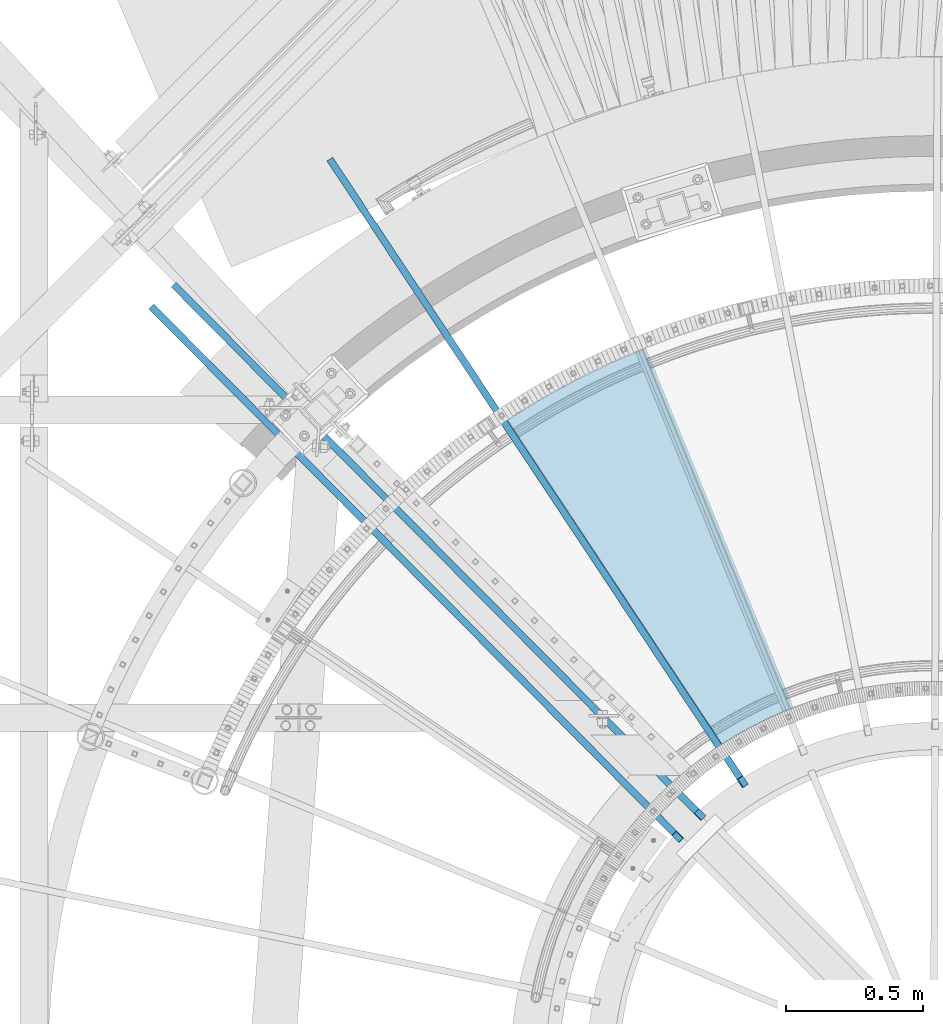
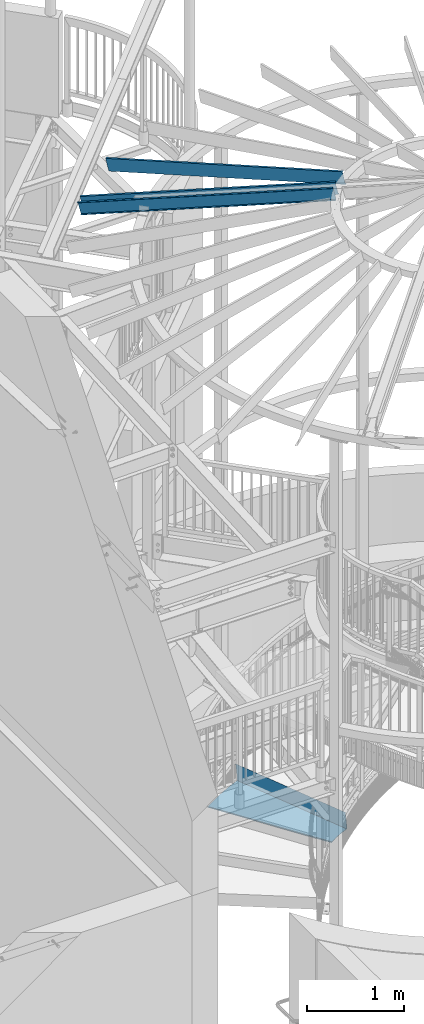
# One storey, part 353 of 975: 4 beams.
"""IFC2X3 building model written with IfcOpenShell, lengths in millimetres."""

import ifcopenshell
import ifcopenshell.guid

model = None  # the IFC model being written
_history = None  # IfcOwnerHistory: only IFC2X3 demands one
_inside = {}  # id of a spatial element -> (the spatial element, [elements in it])
_under = {}  # id of a project, library or spatial element -> (it, [spatial elements below it])
_declared = {}  # id of a project -> (the project, [libraries it declares])
_typed = {}  # id of a type object -> (the type object, [elements of that type])
_made_of = {}  # id of a material, layer set ... -> (it, [elements and type objects made of it])


def new_model(schema):
    """Start an empty IFC model of exactly this schema.

    Asked for "IFC4X3", IfcOpenShell would pick the latest addendum, in which some entities
    have other attributes; the version numbers below select the first issue.
    IFC2X3 requires an IfcOwnerHistory on every rooted entity: one is made here for all.
    """
    global model, _history
    if schema == "IFC4X3":
        model = ifcopenshell.file(schema_version=(4, 3, 0, 0))
    else:
        model = ifcopenshell.file(schema=schema)
    _inside.clear()
    _under.clear()
    _declared.clear()
    _typed.clear()
    _made_of.clear()
    _history = None
    if model.schema == "IFC2X3":
        org = make("IfcOrganization", Name="unknown")
        user = make(
            "IfcPersonAndOrganization",
            ThePerson=make("IfcPerson", FamilyName="unknown"),
            TheOrganization=org,
        )
        app = make(
            "IfcApplication",
            ApplicationDeveloper=org,
            Version="unknown",
            ApplicationFullName="unknown",
            ApplicationIdentifier="unknown",
        )
        _history = make(
            "IfcOwnerHistory",
            OwningUser=user,
            OwningApplication=app,
            ChangeAction="ADDED",
            CreationDate=0,
        )
    return model


def make(cls, **values):
    """One entity of the class cls with the attributes given. An attribute that is None is left unset."""
    return model.create_entity(
        cls, **{name: value for name, value in values.items() if value is not None}
    )


def rooted(cls, **values):
    """An entity with a GlobalId (a new one), such as an element, a storey or a relation."""
    return make(cls, GlobalId=ifcopenshell.guid.new(), OwnerHistory=_history, **values)


def si_unit(unit_type, name, prefix=None):
    """IfcSIUnit, for example si_unit("LENGTHUNIT", "METRE", prefix="MILLI")."""
    return make("IfcSIUnit", UnitType=unit_type, Prefix=prefix, Name=name)


def assignment(units):
    """IfcUnitAssignment: the units of a project."""
    return None if units is None else make("IfcUnitAssignment", Units=units)


def point(xyz):
    """IfcCartesianPoint."""
    return None if xyz is None else make("IfcCartesianPoint", Coordinates=xyz)


def direction(xyz):
    """IfcDirection."""
    return None if xyz is None else make("IfcDirection", DirectionRatios=xyz)


def frame(location, z_axis=None, x_axis=None):
    """IfcAxis2Placement3D, a coordinate frame: its origin and axes. An axis left out is left unset."""
    return make(
        "IfcAxis2Placement3D",
        Location=point(location),
        Axis=direction(z_axis),
        RefDirection=direction(x_axis),
    )


def origin_with_axes():
    """The frame at (0, 0, 0) with the z axis (0, 0, 1) and the x axis (1, 0, 0) written out."""
    return frame((0.0, 0.0, 0.0), z_axis=(0.0, 0.0, 1.0), x_axis=(1.0, 0.0, 0.0))


def place(relative_to, where):
    """IfcLocalPlacement: puts the frame where relative to a parent placement (None: the world)."""
    return make(
        "IfcLocalPlacement", PlacementRelTo=relative_to, RelativePlacement=where
    )


def context(
    kind, dimensions, precision=None, world=None, true_north=None, identifier=None
):
    """IfcGeometricRepresentationContext, for example the 3D "Model" context."""
    return make(
        "IfcGeometricRepresentationContext",
        ContextIdentifier=identifier,
        ContextType=kind,
        CoordinateSpaceDimension=dimensions,
        Precision=precision,
        WorldCoordinateSystem=world,
        TrueNorth=true_north,
    )


def subcontext(parent, identifier, kind, view, scale=None):
    """IfcGeometricRepresentationSubContext, for example "Body" below "Model"."""
    return make(
        "IfcGeometricRepresentationSubContext",
        ContextIdentifier=identifier,
        ContextType=kind,
        ParentContext=parent,
        TargetScale=scale,
        TargetView=view,
    )


def project(units=None, contexts=None):
    """IfcProject with its units and contexts."""
    return rooted(
        "IfcProject",
        Name="project",
        RepresentationContexts=contexts,
        UnitsInContext=assignment(units),
    )


def spatial(cls, under=None, at=None, **own):
    """A site, building, storey or space (cls), placed at a placement, below another one or the project."""
    s = rooted(cls, ObjectPlacement=at, **own)
    if under is not None:
        _under.setdefault(under.id(), (under, []))[1].append(s)
    return s


def faces_of(points, faces, orient=None, outer=None):
    """IfcFace entities. A face is a list of loops; a loop is a list of indices into points, from 0.

    orient and outer hold one flag for each loop. By default every Orientation is true, the
    first loop of a face is its IfcFaceOuterBound and the others are IfcFaceBound.
    """
    made = []
    for i, loops in enumerate(faces):
        bounds = []
        for j, loop in enumerate(loops):
            is_outer = j == 0 if outer is None else outer[i][j]
            bounds.append(
                make(
                    "IfcFaceOuterBound" if is_outer else "IfcFaceBound",
                    Bound=make("IfcPolyLoop", Polygon=[points[k] for k in loop]),
                    Orientation=True if orient is None else orient[i][j],
                )
            )
        made.append(make("IfcFace", Bounds=bounds))
    return made


def faceted_brep(points, faces, orient=None, outer=None, voids=None):
    """IfcFacetedBrep: a solid bounded by flat faces; with voids (closed shells), ...WithVoids."""
    shared = [point(p) for p in points]
    hull = make("IfcClosedShell", CfsFaces=faces_of(shared, faces, orient, outer))
    if voids is None:
        return make("IfcFacetedBrep", Outer=hull)
    return make(
        "IfcFacetedBrepWithVoids",
        Outer=hull,
        Voids=[
            make(cls, CfsFaces=faces_of(shared, fs, o, b)) for cls, fs, o, b in voids
        ],
    )


def shape(context_of_items, identifier, shape_type, items):
    """IfcShapeRepresentation: the items that make up one representation, for example the "Body"."""
    return make(
        "IfcShapeRepresentation",
        ContextOfItems=context_of_items,
        RepresentationIdentifier=identifier,
        RepresentationType=shape_type,
        Items=items,
    )


def material(Name=None, Category=None):
    """IfcMaterial."""
    return make("IfcMaterial", Name=Name, Category=Category)


def made_of(thing, what):
    """Note that an element or type object is made of a material, layer set ...; save() writes the relation."""
    if what is not None:
        _made_of.setdefault(what.id(), (what, []))[1].append(thing)
    return thing


def type_object(cls, material=None, **own):
    """A type object (cls), such as IfcWallType, which elements share."""
    return made_of(rooted(cls, **own), material)


def element(
    cls,
    number,
    at=None,
    inside=None,
    cuts=None,
    type_object=None,
    material=None,
    context=None,
    identifier="Body",
    shape_type=None,
    held_by="IfcProductDefinitionShape",
    body=None,
    shapes=None,
    **own,
):
    """One element of the class cls, such as IfcWall. Its Tag is "e" and its number.

    at: its placement. inside: the storey or other place that contains it. cuts: it is an
    opening in that element (IfcRelVoidsElement). A single representation is given by context,
    identifier, shape_type and body (its items); several are given by shapes. held_by: the class
    of the entity that holds the representations. save() writes the other relations.
    """
    e = rooted(cls, Tag="e%d" % number, ObjectPlacement=at, **own)
    if body is not None:
        shapes = [shape(context, identifier, shape_type, body)]
    if shapes is not None:
        e.Representation = make(held_by, Representations=shapes)
    if inside is not None:
        _inside.setdefault(inside.id(), (inside, []))[1].append(e)
    if cuts is not None:
        rooted(
            "IfcRelVoidsElement", RelatingBuildingElement=cuts, RelatedOpeningElement=e
        )
    if type_object is not None:
        _typed.setdefault(type_object.id(), (type_object, []))[1].append(e)
    return made_of(e, material)


def aggregate(whole, parts):
    """IfcRelAggregates: a whole, such as a stair, and the parts it consists of."""
    return rooted("IfcRelAggregates", RelatingObject=whole, RelatedObjects=parts)


def save(model, path):
    """Write the relations noted so far, then the file.

    IfcRelAggregates (storeys below a building ...), IfcRelContainedInSpatialStructure (elements
    in a storey), IfcRelDefinesByType, IfcRelAssociatesMaterial and IfcRelDeclares: one each for
    every whole, place, type object, material and project.
    """
    for whole, parts in _under.values():
        aggregate(whole, parts)
    for where, things in _inside.values():
        rooted(
            "IfcRelContainedInSpatialStructure",
            RelatedElements=things,
            RelatingStructure=where,
        )
    for kind, things in _typed.values():
        rooted("IfcRelDefinesByType", RelatedObjects=things, RelatingType=kind)
    for what, things in _made_of.values():
        rooted("IfcRelAssociatesMaterial", RelatedObjects=things, RelatingMaterial=what)
    for by, libraries in _declared.values():
        rooted("IfcRelDeclares", RelatingContext=by, RelatedDefinitions=libraries)
    model.write(path)


model = new_model("IFC2X3")

# Units and contexts
model_context = context("Model", 3, precision=1e-05, world=origin_with_axes())
body_context = subcontext(model_context, "Body", "Model", "MODEL_VIEW")
ifc_project = project(units=[si_unit("LENGTHUNIT", "METRE", prefix="MILLI"), si_unit("AREAUNIT", "SQUARE_METRE"), si_unit("VOLUMEUNIT", "CUBIC_METRE"), si_unit("MASSUNIT", "GRAM", prefix="KILO"), si_unit("TIMEUNIT", "SECOND"), si_unit("PLANEANGLEUNIT", "RADIAN"), si_unit("SOLIDANGLEUNIT", "STERADIAN"), si_unit("THERMODYNAMICTEMPERATUREUNIT", "DEGREE_CELSIUS"), si_unit("LUMINOUSINTENSITYUNIT", "LUMEN")], contexts=[model_context])

# Site, building, storey
site_placement = place(None, origin_with_axes())
site = spatial("IfcSite", under=ifc_project, at=site_placement, CompositionType="ELEMENT")
building_placement = place(site_placement, origin_with_axes())
building = spatial("IfcBuilding", under=site, at=building_placement, Name="Undefined", CompositionType="ELEMENT")
storey_placement = place(building_placement, origin_with_axes())
storey = spatial("IfcBuildingStorey", under=building, at=storey_placement, Name="Undefined", CompositionType="ELEMENT", Elevation=0.0)

# Beams
ifc_material_1 = material(Name="STEEL/A36")
beam_type_1 = type_object("IfcBeamType", PredefinedType="NOTDEFINED")
beam_placement = place(storey_placement, frame((33918.0224057617, 5435.90613821001, 692.116955742185), z_axis=(-0.379912314965979, 0.925022504016627, -3.77856395061827e-11), x_axis=(-0.654089685261445, -0.268638574107448, 0.707106781282786)))
element("IfcBeam", 1, at=beam_placement, inside=storey, type_object=beam_type_1, material=ifc_material_1, Name="TREAD", context=body_context, shape_type="Brep", body=[
    faceted_brep([(25.4000001621371, 1.5874997143419, 653.28751700326), (1.61144271260127e-08, 1.58750000026703, 653.458911680114), (-1.96268956642598e-08, -1.58749999973588, 653.437487347819), (15.8745748038546, -1.5875001784334, 653.330368544412), (-120.373022221533, -103.76749224318, 653.560250726816), (-154.208562872085, -137.603032237963, 653.560249286144), (-49.0005534961238, -242.811041643061, 652.140399877677), (-46.7554894721361, -240.565977619684, 652.140399877557), (-149.718432901582, -137.603030988068, 653.529952160912), (-118.287540217565, -106.172138299769, 653.529952144057), (82.2634121742994, -374.075007349978, 638.193006315465), (84.508476198167, -371.829943326711, 638.193006315345), (212.601306559884, -504.412901568812, 612.134347567509), (214.846370562875, -502.167837565145, 612.134347570151), (261.055176792581, -530.596712595621, 601.111823144849), (259.197053542079, -528.103470062568, 601.754434690294), (248.701623596196, -536.023091227627, 602.134831213494), (248.362633442506, -540.174228440612, 601.571851715846), (250.921725105154, -538.24319290819, 601.479100122608), (25.4000001865188, 1.58749971376164, -768.618736200977), (-118.287540216395, -106.172138302336, -768.542582766611), (-149.718433278054, -137.603031368186, -768.542582749815), (-92.8426928760819, -194.478774201189, -768.783692225286), (-95.087756899542, -196.723838224048, -768.783692225159), (-154.208562871598, -137.603032235413, -768.533065523057), (-120.373022220361, -103.767492245748, -768.533065418116), (15.8745748282345, -1.58750017901184, -768.605275732323), (-1.58015609486029e-08, -1.58750000031432, -768.571627720263), (1.99397618416697e-08, 1.58749999968677, -768.564897939472), (-21.2434099455131, -266.078057151808, -776.330856581004), (-23.4884739689005, -268.323121174595, -776.330856580884), (49.7927349215133, -337.114201961485, -791.08236047571), (47.5476709198538, -339.35926596382, -791.082360478347), (66.437802308692, -335.979336534963, -793.502619428495), (56.3071310127107, -343.628597994977, -793.115412720523), (53.7487404151489, -345.560335457225, -793.01762786691), (54.0919957188744, -341.413461775162, -792.424099714608), (64.5845451579717, -333.490960101732, -792.825137753654)], [[[0, 1, 2, 3, 4, 5, 6, 7, 8, 9]], [[7, 6, 10, 11]], [[11, 10, 12, 13]], [[14, 15, 16, 13, 12, 17, 18]], [[19, 20, 21, 22, 23, 24, 25, 26, 27, 28]], [[29, 30, 23, 22]], [[31, 32, 30, 29]], [[33, 34, 35, 32, 31, 36, 37]], [[34, 33, 14, 18]], [[35, 34, 18, 17]], [[10, 6, 5, 24, 23, 30, 32, 35, 17, 12]], [[25, 24, 5, 4]], [[26, 25, 4, 3]], [[27, 26, 3, 2]], [[28, 27, 2, 1]], [[19, 28, 1, 0]], [[20, 19, 0, 9]], [[20, 9, 8, 21]], [[36, 31, 29, 22, 21, 8, 7, 11, 13, 16]], [[37, 36, 16, 15]], [[33, 37, 15, 14]]]),
])
ifc_material_2 = material(Name="STEEL/Zero_Density")
beam_type_2 = type_object("IfcBeamType", PredefinedType="NOTDEFINED")
for number, where, z_axis, x_axis, name in (
    (2, (34034.9322722468, 4458.29973680554, 8885.0313138005), (-0.134009290222391, 0.202158604335487, 0.97014092214854), (-0.536022339859084, 0.808612057787423, -0.242541936936238), "STUD"),
    (3, (33878.7320192485, 4337.67455015727, 8885.0313138005), (-0.170873527176511, 0.172130267177808, 0.970140922150774), (-0.683475207795134, 0.688502032793624, -0.242541936927299), "STUD"),
    (4, (31884.6249053099, 6184.30262192325, 8206.16015010101), (-0.170873527176511, 0.172130267177808, 0.970140922150774), (0.683475126987411, -0.688502112987316, 0.242541936995532), "STUD"),
):
    element("IfcBeam", number, at=place(storey_placement, frame(where, z_axis=z_axis, x_axis=x_axis)), inside=storey, type_object=beam_type_2, material=ifc_material_2, Name=name, context=body_context, shape_type="Brep", body=[
        faceted_brep([(-1.67347025126219e-10, 12.6999999998588, -76.2000000000985), (1.96450855582952e-10, 12.7000000001644, 76.2000000001021), (2798.98467503002, 12.7000000041553, 76.2000000028588), (2798.98467502966, 12.7000000038533, -76.1999999973427), (1.74622982740402e-10, -12.6999999998661, 76.2000000000985), (2798.98467503, -12.6999999958753, 76.2000000028534), (1.67347025126219e-10, -12.6999999998698, 73.0250000000947), (2798.98467502999, -12.6999999958789, 73.0250000028504), (1.89174897968769e-10, 9.52500000015425, 73.0250000000974), (2798.98467503001, 9.52500000414511, 73.0250000028532), (-1.60071067512035e-10, 9.52499999986321, -73.0250000000938), (2798.98467502966, 9.52500000385407, -73.0249999973398), (-1.81898940354586e-10, -12.7000000001608, -73.0250000000965), (2798.98467502964, -12.6999999961699, -73.0249999973416), (-1.92812876775861e-10, -12.7000000001717, -76.2000000001003), (2798.98467502963, -12.6999999961772, -76.1999999973455)], [[[0, 1, 2, 3]], [[1, 4, 5, 2]], [[4, 6, 7, 5]], [[6, 8, 9, 7]], [[8, 10, 11, 9]], [[10, 12, 13, 11]], [[12, 14, 15, 13]], [[14, 0, 3, 15]], [[5, 7, 9, 11, 13, 15, 3, 2]], [[14, 12, 10, 8, 6, 4, 1, 0]]]),
    ])

save(model, "model.ifc")
